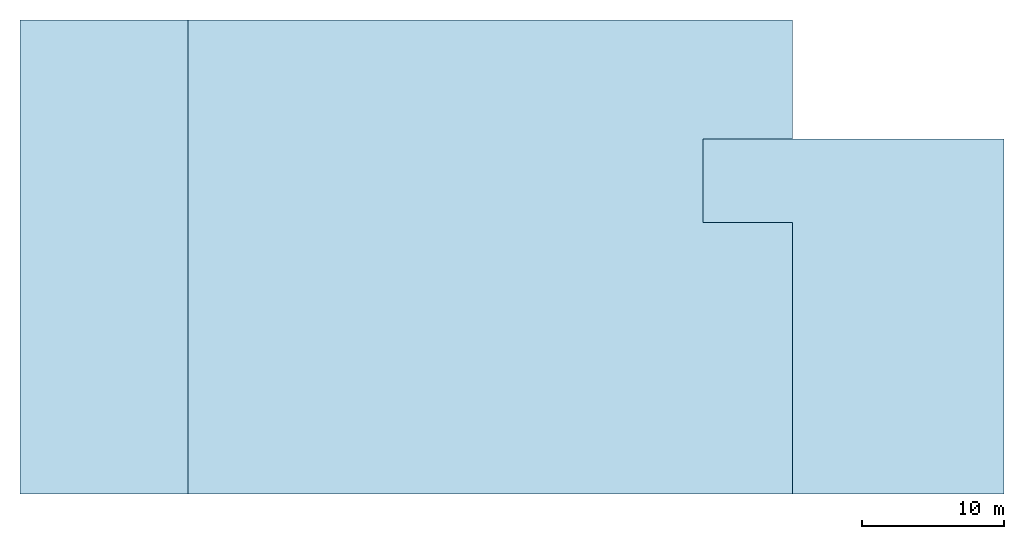
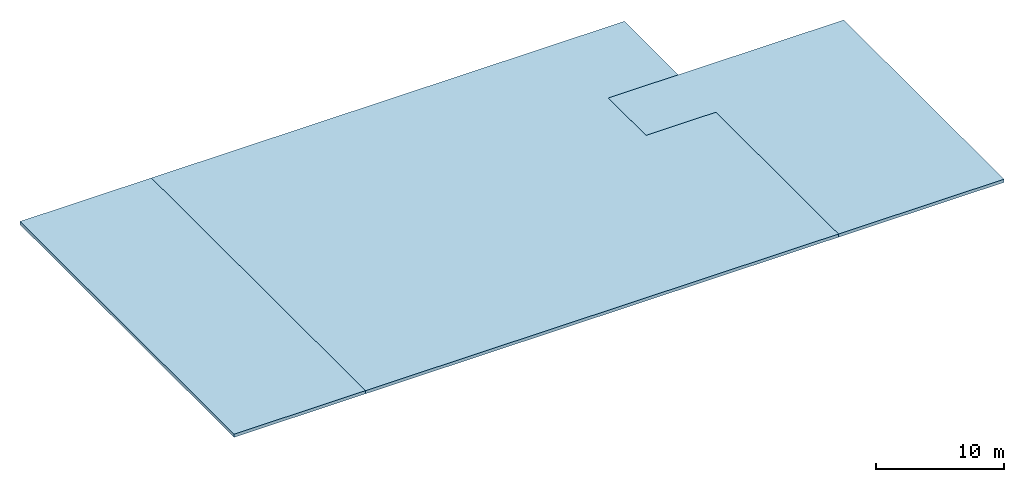
# One storey: 3 footings.
"""IFC2X3 building model written with IfcOpenShell, lengths in millimetres."""

from ifc_helpers import new_model, entity, si_unit, converted_unit, frame, origin, place, context, subcontext, project, spatial, faceted_brep, material, element, save


model = new_model("IFC2X3")

# Units and contexts
model_context = context("Model", 3, precision=1e-05, world=origin())
body_context = subcontext(model_context, "Body", "Model", "MODEL_VIEW")
ifc_project = project(units=[si_unit("LENGTHUNIT", "METRE", prefix="MILLI"), converted_unit("PLANEANGLEUNIT", "DEGREE", entity("IfcPlaneAngleMeasure", 0.0174532925199433), si_unit("PLANEANGLEUNIT", "RADIAN"), dimensions=[0, 0, 0, 0, 0, 0, 0]), si_unit("AREAUNIT", "SQUARE_METRE"), si_unit("VOLUMEUNIT", "CUBIC_METRE")], contexts=[model_context])

# Building, storey
building_placement = place(None, origin())
building = spatial("IfcBuilding", under=ifc_project, at=building_placement, CompositionType="ELEMENT")
storey_placement = place(building_placement, frame((0.0, 0.0, -800.0), z_axis=(0.0, 0.0, 1.0), x_axis=(1.0, 0.0, 0.0)))
storey = spatial("IfcBuildingStorey", under=building, at=storey_placement, Name="Fundament", CompositionType="ELEMENT", Elevation=-800.0)

# Footings
ifc_material_1 = material(Name="Beton")
footing_1_placement = place(storey_placement, frame((11829.99, -0.00999999999839929, 499.99), z_axis=(0.0, 0.0, 1.0), x_axis=(1.0, 0.0, 0.0)))
element("IfcFooting", 1, at=footing_1_placement, inside=storey, material=ifc_material_1, PredefinedType="NOTDEFINED", context=body_context, shape_type="Brep", body=[
    faceted_brep([(36300.01, 25000.01, 0.009999999999990905), (42600.01000000001, 25000.01, 0.009999999999990905), (42600.01000000011, 33400.01, 0.009999999999990905), (0.00999999999839929, 33400.01, 0.009999999999990905), (0.00999999999839929, 0.00999999999839929, 0.009999999999990905), (42600.01000000001, 0.00999999999839929, 0.009999999999990905), (42600.01000000005, 19125.00999999978, 0.009999999999990905), (36300.01000000004, 19125.0099999998, 0.009999999999990905), (42600.01000000001, 25000.01, 300.01), (36300.01, 25000.01, 300.01), (36300.01000000004, 19125.0099999998, 300.01), (42600.01000000005, 19125.00999999978, 300.01), (42600.01000000001, 0.00999999999839929, 300.01), (0.00999999999839929, 0.00999999999839929, 300.01), (0.00999999999839929, 33400.01, 300.01), (42600.01000000011, 33400.01, 300.01), (42600.01000000001, 25000.01, 0.009999999999990905), (36300.01, 25000.01, 0.009999999999990905), (36300.01, 25000.01, 300.01), (42600.01000000001, 25000.01, 300.01), (42600.01000000011, 33400.01, 0.009999999999990905), (42600.01000000001, 25000.01, 0.009999999999990905), (42600.01000000001, 25000.01, 300.01), (42600.01000000011, 33400.01, 300.01), (0.00999999999839929, 33400.01, 0.009999999999990905), (42600.01000000011, 33400.01, 0.009999999999990905), (42600.01000000011, 33400.01, 300.01), (0.00999999999839929, 33400.01, 300.01), (0.00999999999839929, 0.00999999999839929, 0.009999999999990905), (0.00999999999839929, 33400.01, 0.009999999999990905), (0.00999999999839929, 33400.01, 300.01), (0.00999999999839929, 0.00999999999839929, 300.01), (42600.01000000001, 0.00999999999839929, 0.009999999999990905), (0.00999999999839929, 0.00999999999839929, 0.009999999999990905), (0.00999999999839929, 0.00999999999839929, 300.01), (42600.01000000001, 0.00999999999839929, 300.01), (42600.01000000005, 19125.00999999978, 0.009999999999990905), (42600.01000000001, 0.00999999999839929, 0.009999999999990905), (42600.01000000001, 0.00999999999839929, 300.01), (42600.01000000005, 19125.00999999978, 300.01), (36300.01000000004, 19125.0099999998, 0.009999999999990905), (42600.01000000005, 19125.00999999978, 0.009999999999990905), (42600.01000000005, 19125.00999999978, 300.01), (36300.01000000004, 19125.0099999998, 300.01), (36300.01, 25000.01, 0.009999999999990905), (36300.01000000004, 19125.0099999998, 0.009999999999990905), (36300.01000000004, 19125.0099999998, 300.01), (36300.01, 25000.01, 300.01)], [[[0, 1, 2, 3, 4, 5, 6, 7]], [[8, 9, 10, 11, 12, 13, 14, 15]], [[16, 17, 18, 19]], [[20, 21, 22, 23]], [[24, 25, 26, 27]], [[28, 29, 30, 31]], [[32, 33, 34, 35]], [[36, 37, 38, 39]], [[40, 41, 42, 43]], [[44, 45, 46, 47]]], orient=[[False], [False], [False], [False], [False], [False], [False], [False], [False], [False]]),
])
ifc_material_2 = material(Name="Beton")
footing_2_placement = place(storey_placement, frame((-0.01000000000021828, -0.00999999999839929, 499.99), z_axis=(0.0, 0.0, 1.0), x_axis=(1.0, 0.0, 0.0)))
element("IfcFooting", 2, at=footing_2_placement, inside=storey, material=ifc_material_2, PredefinedType="NOTDEFINED", context=body_context, shape_type="Brep", body=[
    faceted_brep([(11830.01, 0.00999999999839929, 0.009999999999990905), (11830.01, 33400.01, 0.009999999999990905), (0.01000000000021828, 33400.01, 0.009999999999990905), (0.01000000000021828, 0.00999999999839929, 0.009999999999990905), (11830.01, 33400.01, 300.01), (11830.01, 0.00999999999839929, 300.01), (0.01000000000021828, 0.00999999999839929, 300.01), (0.01000000000021828, 33400.01, 300.01), (11830.01, 33400.01, 0.009999999999990905), (11830.01, 0.00999999999839929, 0.009999999999990905), (11830.01, 0.00999999999839929, 300.01), (11830.01, 33400.01, 300.01), (0.01000000000021828, 33400.01, 0.009999999999990905), (11830.01, 33400.01, 0.009999999999990905), (11830.01, 33400.01, 300.01), (0.01000000000021828, 33400.01, 300.01), (0.01000000000021828, 0.00999999999839929, 0.009999999999990905), (0.01000000000021828, 33400.01, 0.009999999999990905), (0.01000000000021828, 33400.01, 300.01), (0.01000000000021828, 0.00999999999839929, 300.01), (11830.01, 0.00999999999839929, 0.009999999999990905), (0.01000000000021828, 0.00999999999839929, 0.009999999999990905), (0.01000000000021828, 0.00999999999839929, 300.01), (11830.01, 0.00999999999839929, 300.01)], [[[0, 1, 2, 3]], [[4, 5, 6, 7]], [[8, 9, 10, 11]], [[12, 13, 14, 15]], [[16, 17, 18, 19]], [[20, 21, 22, 23]]], orient=[[False], [False], [False], [False], [False], [False]]),
])
ifc_material_3 = material(Name="Beton")
footing_3_placement = place(storey_placement, frame((48129.99, -0.01000000000021828, 499.99), z_axis=(0.0, 0.0, 1.0), x_axis=(1.0, 0.0, 0.0)))
element("IfcFooting", 3, at=footing_3_placement, inside=storey, material=ifc_material_3, PredefinedType="NOTDEFINED", context=body_context, shape_type="Brep", body=[
    faceted_brep([(21200.01, 25000.01000000037, 0.009999999999990905), (0.01000000000203727, 25000.01, 0.009999999999990905), (0.01000000003841706, 19125.0099999998, 0.009999999999990905), (6300.010000000053, 19125.00999999978, 0.009999999999990905), (6300.010000000009, 0.01000000000021828, 0.009999999999990905), (21200.01, 0.01000000037129212, 0.009999999999990905), (0.01000000000203727, 25000.01, 300.01), (21200.01, 25000.01000000037, 300.01), (21200.01, 0.01000000037129212, 300.01), (6300.010000000009, 0.01000000000021828, 300.01), (6300.010000000053, 19125.00999999978, 300.01), (0.01000000003841706, 19125.0099999998, 300.01), (0.01000000000203727, 25000.01, 0.009999999999990905), (21200.01, 25000.01000000037, 0.009999999999990905), (21200.01, 25000.01000000037, 300.01), (0.01000000000203727, 25000.01, 300.01), (0.01000000003841706, 19125.0099999998, 0.009999999999990905), (0.01000000000203727, 25000.01, 0.009999999999990905), (0.01000000000203727, 25000.01, 300.01), (0.01000000003841706, 19125.0099999998, 300.01), (6300.010000000053, 19125.00999999978, 0.009999999999990905), (0.01000000003841706, 19125.0099999998, 0.009999999999990905), (0.01000000003841706, 19125.0099999998, 300.01), (6300.010000000053, 19125.00999999978, 300.01), (6300.010000000009, 0.01000000000021828, 0.009999999999990905), (6300.010000000053, 19125.00999999978, 0.009999999999990905), (6300.010000000053, 19125.00999999978, 300.01), (6300.010000000009, 0.01000000000021828, 300.01), (21200.01, 0.01000000037129212, 0.009999999999990905), (6300.010000000009, 0.01000000000021828, 0.009999999999990905), (6300.010000000009, 0.01000000000021828, 300.01), (21200.01, 0.01000000037129212, 300.01), (21200.01, 25000.01000000037, 0.009999999999990905), (21200.01, 0.01000000037129212, 0.009999999999990905), (21200.01, 0.01000000037129212, 300.01), (21200.01, 25000.01000000037, 300.01)], [[[0, 1, 2, 3, 4, 5]], [[6, 7, 8, 9, 10, 11]], [[12, 13, 14, 15]], [[16, 17, 18, 19]], [[20, 21, 22, 23]], [[24, 25, 26, 27]], [[28, 29, 30, 31]], [[32, 33, 34, 35]]], orient=[[False], [False], [False], [False], [False], [False], [False], [False]]),
])

save(model, "model.ifc")
